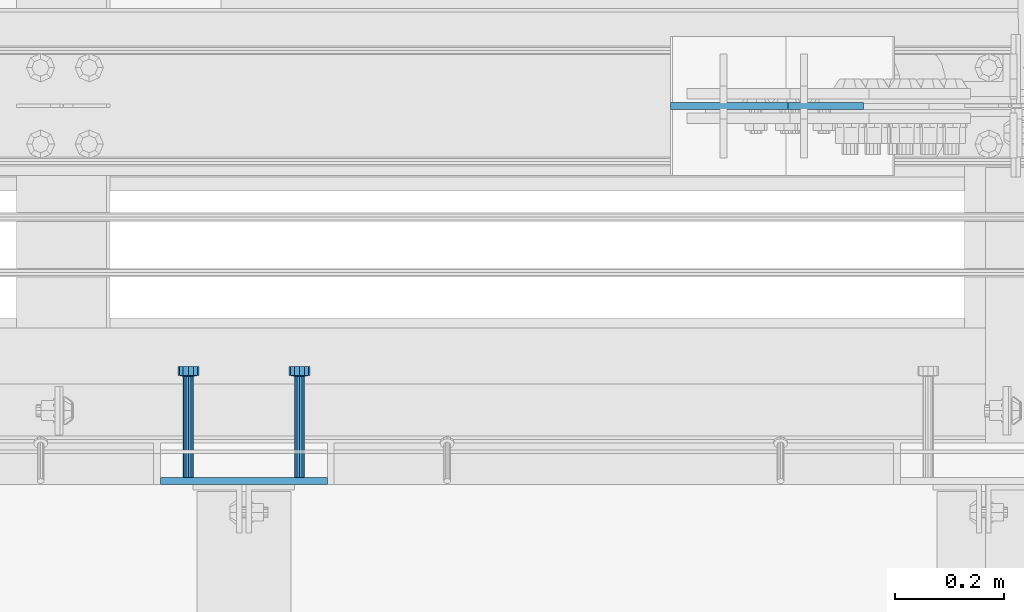
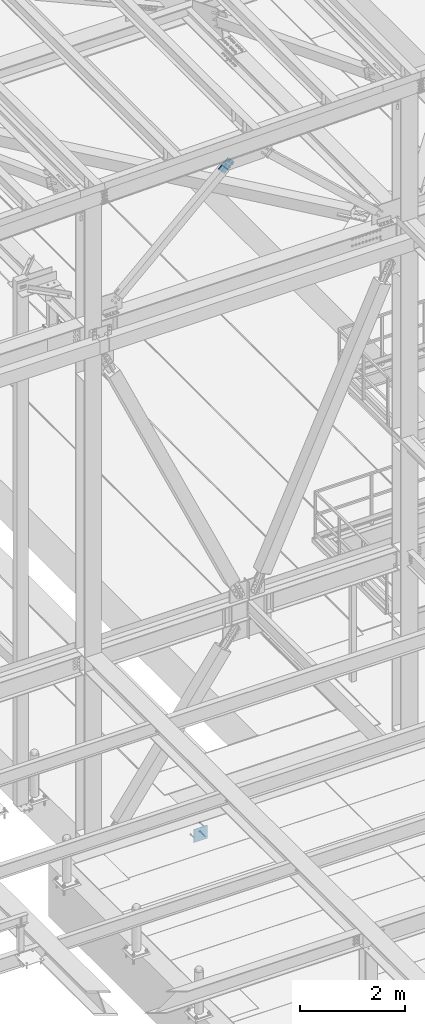
# One storey, part 2024 of 3843: 4 beams, 1 member, 2 elements without a shape of their own.
"""IFC2X3 building model written with IfcOpenShell, lengths in millimetres."""

from ifc_helpers import new_model, si_unit, frame, origin_with_axes, place, context, subcontext, project, spatial, faceted_brep, material, type_object, element, aggregate, save


model = new_model("IFC2X3")

# Units and contexts
model_context = context("Model", 3, precision=1e-05, world=origin_with_axes())
body_context = subcontext(model_context, "Body", "Model", "MODEL_VIEW")
ifc_project = project(units=[si_unit("LENGTHUNIT", "METRE", prefix="MILLI"), si_unit("AREAUNIT", "SQUARE_METRE"), si_unit("VOLUMEUNIT", "CUBIC_METRE"), si_unit("MASSUNIT", "GRAM", prefix="KILO"), si_unit("TIMEUNIT", "SECOND"), si_unit("PLANEANGLEUNIT", "RADIAN"), si_unit("SOLIDANGLEUNIT", "STERADIAN"), si_unit("THERMODYNAMICTEMPERATUREUNIT", "DEGREE_CELSIUS"), si_unit("LUMINOUSINTENSITYUNIT", "LUMEN")], contexts=[model_context])

# Site, building, storey
site_placement = place(None, origin_with_axes())
site = spatial("IfcSite", under=ifc_project, at=site_placement, CompositionType="ELEMENT")
building_placement = place(site_placement, origin_with_axes())
building = spatial("IfcBuilding", under=site, at=building_placement, Name="Undefined", CompositionType="ELEMENT")
storey_placement = place(building_placement, origin_with_axes())
storey = spatial("IfcBuildingStorey", under=building, at=storey_placement, Name="Undefined", CompositionType="ELEMENT", Elevation=0.0)

# Assembly, beam
assembly_1_placement = place(storey_placement, origin_with_axes())
assembly_1 = element("IfcElementAssembly", 1, at=assembly_1_placement, inside=storey, Name="EMBED PLATE", AssemblyPlace="NOTDEFINED", PredefinedType="RIGID_FRAME")
ifc_material_1 = material(Name="STEEL/A36")
beam_type_1 = type_object("IfcBeamType", PredefinedType="NOTDEFINED")
beam_1_placement = place(assembly_1_placement, frame((44122.975, 24930.0999969483, 30397.45), z_axis=(1.0, 0.0, 0.0), x_axis=(0.0, 0.0, -1.0)))
beam_1 = element("IfcBeam", 2, at=beam_1_placement, type_object=beam_type_1, material=ifc_material_1, Name="EMBED PLATE", context=body_context, shape_type="Brep", body=[
    faceted_brep([(-1.0550138540566e-10, 6.34999999999854, -152.400000000664), (1.0550138540566e-10, 6.34999999999854, 152.400000000656), (304.799999999999, 6.34999999999854, 152.400000000001), (304.799999999999, 6.34999999999854, -152.400000000001), (1.0550138540566e-10, -6.34999999999854, 152.400000000656), (304.799999999999, -6.34999999999854, 152.400000000001), (-1.0550138540566e-10, -6.34999999999854, -152.400000000664), (304.799999999999, -6.34999999999854, -152.400000000001)], [[[0, 1, 2, 3]], [[1, 4, 5, 2]], [[4, 6, 7, 5]], [[6, 0, 3, 7]], [[5, 7, 3, 2]], [[6, 4, 1, 0]]]),
])

# Assembly, member
assembly_2_placement = place(storey_placement, origin_with_axes())
assembly_2 = element("IfcElementAssembly", 3, at=assembly_2_placement, inside=storey, AssemblyPlace="NOTDEFINED", PredefinedType="RIGID_FRAME")
ifc_material_2 = material(Name="STEEL/A572-50")
member_type = type_object("IfcMemberType", PredefinedType="NOTDEFINED")
member_placement = place(assembly_2_placement, frame((45186.5607514104, 25615.8999999454, 45083.0309669652), z_axis=(0.678515287903944, 0.0, -0.734586280896007), x_axis=(-0.734586280896004, 0.0, -0.678515287903948)))
member = element("IfcMember", 4, at=member_placement, type_object=member_type, material=ifc_material_2, Name="PLATE", context=body_context, shape_type="Brep", body=[
    faceted_brep([(1.74622982740402e-10, 6.35000000000582, -101.600000000195), (-1.67347025126219e-10, 6.35000000000582, 101.600000000151), (292.1000000028, 6.35000000000582, 101.600000000661), (292.100000003156, 6.35000000000582, -101.599999999686), (-1.67347025126219e-10, -6.35000000000582, 101.600000000151), (292.1000000028, -6.35000000000582, 101.600000000661), (1.74622982740402e-10, -6.35000000000582, -101.600000000195), (292.100000003156, -6.35000000000582, -101.599999999686)], [[[0, 1, 2, 3]], [[1, 4, 5, 2]], [[4, 6, 7, 5]], [[6, 0, 3, 7]], [[5, 7, 3, 2]], [[6, 4, 1, 0]]]),
])
aggregate(assembly_2, [member])

# Beam
ifc_material_3 = material(Name="STEEL/A108")
beam_type_2 = type_object("IfcBeamType", PredefinedType="NOTDEFINED")
beam_2_placement = place(assembly_1_placement, frame((44021.375, 24936.4499969483, 30143.45), z_axis=(-1.0, 0.0, 0.0), x_axis=(0.0, 1.0, 0.0)))
beam_2 = element("IfcBeam", 5, at=beam_2_placement, type_object=beam_type_2, material=ifc_material_3, Name="HEADED STUD ANCHOR", context=body_context, shape_type="Brep", body=[
    faceted_brep([(0.0, -9.52000045776367, 0.0), (0.0, -8.25, -4.76000022888184), (184.912000000004, -8.25, -4.76000022888184), (184.912000000004, -9.52000045776367, 0.0), (0.0, -4.76000022888184, -8.25), (184.912000000004, -4.76000022888184, -8.25), (0.0, 0.0, -9.52000045776367), (184.912000000004, 0.0, -9.52000045776367), (0.0, 4.76000022888184, -8.25), (184.912000000004, 4.76000022888184, -8.25), (0.0, 8.25, -4.76000022888184), (184.912000000004, 8.25, -4.76000022888184), (0.0, 9.52000045776367, 0.0), (184.912000000004, 9.52000045776367, 0.0), (0.0, 8.25, 4.76000022888184), (184.912000000004, 8.25, 4.76000022888184), (0.0, 4.76000022888184, 8.25), (184.912000000004, 4.76000022888184, 8.25), (0.0, 0.0, 9.52000045776367), (184.912000000004, 0.0, 9.52000045776367), (0.0, -4.76000022888184, 8.25), (184.912000000004, -4.76000022888184, 8.25), (0.0, -8.25, 4.76000022888184), (184.912000000004, -8.25, 4.76000022888184), (186.944000000003, -16.5, -9.52000045776367), (186.944000000003, -19.0499992370605, 0.0), (186.944000000003, -9.52000045776367, -16.5), (186.944000000003, 0.0, -19.0499992370605), (186.944000000003, 9.52000045776367, -16.5), (186.944000000003, 16.5, -9.52000045776367), (186.944000000003, 19.0499992370605, 0.0), (186.944000000003, 16.5, 9.52000045776367), (186.944000000003, 9.52000045776367, 16.5), (186.944000000003, 0.0, 19.0499992370605), (186.944000000003, -9.52000045776367, 16.5), (186.944000000003, -16.5, 9.52000045776367), (203.199999999997, -16.5, -9.52000045776367), (203.199999999997, -19.0499992370605, 0.0), (203.199999999997, -9.52000045776367, -16.5), (203.199999999997, 0.0, -19.0499992370605), (203.199999999997, 9.52000045776367, -16.5), (203.199999999997, 16.5, -9.52000045776367), (203.199999999997, 19.0499992370605, 0.0), (203.199999999997, 16.5, 9.52000045776367), (203.199999999997, 9.52000045776367, 16.5), (203.199999999997, 0.0, 19.0499992370605), (203.199999999997, -9.52000045776367, 16.5), (203.199999999997, -16.5, 9.52000045776367)], [[[0, 1, 2, 3]], [[1, 4, 5, 2]], [[4, 6, 7, 5]], [[6, 8, 9, 7]], [[8, 10, 11, 9]], [[10, 12, 13, 11]], [[12, 14, 15, 13]], [[14, 16, 17, 15]], [[16, 18, 19, 17]], [[18, 20, 21, 19]], [[20, 22, 23, 21]], [[22, 0, 3, 23]], [[22, 20, 18, 16, 14, 12, 10, 8, 6, 4, 1, 0]], [[3, 2, 24, 25]], [[2, 5, 26, 24]], [[5, 7, 27, 26]], [[7, 9, 28, 27]], [[9, 11, 29, 28]], [[11, 13, 30, 29]], [[13, 15, 31, 30]], [[15, 17, 32, 31]], [[17, 19, 33, 32]], [[19, 21, 34, 33]], [[21, 23, 35, 34]], [[23, 3, 25, 35]], [[25, 24, 36, 37]], [[24, 26, 38, 36]], [[26, 27, 39, 38]], [[27, 28, 40, 39]], [[28, 29, 41, 40]], [[29, 30, 42, 41]], [[30, 31, 43, 42]], [[31, 32, 44, 43]], [[32, 33, 45, 44]], [[33, 34, 46, 45]], [[34, 35, 47, 46]], [[35, 25, 37, 47]], [[38, 39, 40, 41, 42, 43, 44, 45, 46, 47, 37, 36]]]),
])

beam_3_placement = place(assembly_1_placement, frame((44224.575, 24936.4499969483, 30346.65), z_axis=(-1.0, 0.0, 0.0), x_axis=(0.0, 1.0, 0.0)))
beam_3 = element("IfcBeam", 6, at=beam_3_placement, type_object=beam_type_2, material=ifc_material_1, Name="PLATE", context=body_context, shape_type="Brep", body=[
    faceted_brep([(0.0, -9.52000045776367, 0.0), (0.0, -8.25, -4.76000022888184), (184.912000000004, -8.25, -4.76000022888184), (184.912000000004, -9.52000045776367, 0.0), (0.0, -4.76000022888184, -8.25), (184.912000000004, -4.76000022888184, -8.25), (0.0, 0.0, -9.52000045776367), (184.912000000004, 0.0, -9.52000045776367), (0.0, 4.76000022888184, -8.25), (184.912000000004, 4.76000022888184, -8.25), (0.0, 8.25, -4.76000022888184), (184.912000000004, 8.25, -4.76000022888184), (0.0, 9.52000045776367, 0.0), (184.912000000004, 9.52000045776367, 0.0), (0.0, 8.25, 4.76000022888184), (184.912000000004, 8.25, 4.76000022888184), (0.0, 4.76000022888184, 8.25), (184.912000000004, 4.76000022888184, 8.25), (0.0, 0.0, 9.52000045776367), (184.912000000004, 0.0, 9.52000045776367), (0.0, -4.76000022888184, 8.25), (184.912000000004, -4.76000022888184, 8.25), (0.0, -8.25, 4.76000022888184), (184.912000000004, -8.25, 4.76000022888184), (186.944000000003, -16.5, -9.52000045776367), (186.944000000003, -19.0499992370605, 0.0), (186.944000000003, -9.52000045776367, -16.5), (186.944000000003, 0.0, -19.0499992370605), (186.944000000003, 9.52000045776367, -16.5), (186.944000000003, 16.5, -9.52000045776367), (186.944000000003, 19.0499992370605, 0.0), (186.944000000003, 16.5, 9.52000045776367), (186.944000000003, 9.52000045776367, 16.5), (186.944000000003, 0.0, 19.0499992370605), (186.944000000003, -9.52000045776367, 16.5), (186.944000000003, -16.5, 9.52000045776367), (203.199999999997, -16.5, -9.52000045776367), (203.199999999997, -19.0499992370605, 0.0), (203.199999999997, -9.52000045776367, -16.5), (203.199999999997, 0.0, -19.0499992370605), (203.199999999997, 9.52000045776367, -16.5), (203.199999999997, 16.5, -9.52000045776367), (203.199999999997, 19.0499992370605, 0.0), (203.199999999997, 16.5, 9.52000045776367), (203.199999999997, 9.52000045776367, 16.5), (203.199999999997, 0.0, 19.0499992370605), (203.199999999997, -9.52000045776367, 16.5), (203.199999999997, -16.5, 9.52000045776367)], [[[0, 1, 2, 3]], [[1, 4, 5, 2]], [[4, 6, 7, 5]], [[6, 8, 9, 7]], [[8, 10, 11, 9]], [[10, 12, 13, 11]], [[12, 14, 15, 13]], [[14, 16, 17, 15]], [[16, 18, 19, 17]], [[18, 20, 21, 19]], [[20, 22, 23, 21]], [[22, 0, 3, 23]], [[22, 20, 18, 16, 14, 12, 10, 8, 6, 4, 1, 0]], [[3, 2, 24, 25]], [[2, 5, 26, 24]], [[5, 7, 27, 26]], [[7, 9, 28, 27]], [[9, 11, 29, 28]], [[11, 13, 30, 29]], [[13, 15, 31, 30]], [[15, 17, 32, 31]], [[17, 19, 33, 32]], [[19, 21, 34, 33]], [[21, 23, 35, 34]], [[23, 3, 25, 35]], [[25, 24, 36, 37]], [[24, 26, 38, 36]], [[26, 27, 39, 38]], [[27, 28, 40, 39]], [[28, 29, 41, 40]], [[29, 30, 42, 41]], [[30, 31, 43, 42]], [[31, 32, 44, 43]], [[32, 33, 45, 44]], [[33, 34, 46, 45]], [[34, 35, 47, 46]], [[35, 25, 37, 47]], [[38, 39, 40, 41, 42, 43, 44, 45, 46, 47, 37, 36]]]),
])

beam_4_placement = place(assembly_1_placement, frame((44224.575, 24936.4499969483, 30143.45), z_axis=(-1.0, 0.0, 0.0), x_axis=(0.0, 1.0, 0.0)))
beam_4 = element("IfcBeam", 7, at=beam_4_placement, type_object=beam_type_2, material=ifc_material_3, Name="HEADED STUD ANCHOR", context=body_context, shape_type="Brep", body=[
    faceted_brep([(0.0, -9.52000045776367, 0.0), (0.0, -8.25, -4.76000022888184), (184.912000000004, -8.25, -4.76000022888184), (184.912000000004, -9.52000045776367, 0.0), (0.0, -4.76000022888184, -8.25), (184.912000000004, -4.76000022888184, -8.25), (0.0, 0.0, -9.52000045776367), (184.912000000004, 0.0, -9.52000045776367), (0.0, 4.76000022888184, -8.25), (184.912000000004, 4.76000022888184, -8.25), (0.0, 8.25, -4.76000022888184), (184.912000000004, 8.25, -4.76000022888184), (0.0, 9.52000045776367, 0.0), (184.912000000004, 9.52000045776367, 0.0), (0.0, 8.25, 4.76000022888184), (184.912000000004, 8.25, 4.76000022888184), (0.0, 4.76000022888184, 8.25), (184.912000000004, 4.76000022888184, 8.25), (0.0, 0.0, 9.52000045776367), (184.912000000004, 0.0, 9.52000045776367), (0.0, -4.76000022888184, 8.25), (184.912000000004, -4.76000022888184, 8.25), (0.0, -8.25, 4.76000022888184), (184.912000000004, -8.25, 4.76000022888184), (186.944000000003, -16.5, -9.52000045776367), (186.944000000003, -19.0499992370605, 0.0), (186.944000000003, -9.52000045776367, -16.5), (186.944000000003, 0.0, -19.0499992370605), (186.944000000003, 9.52000045776367, -16.5), (186.944000000003, 16.5, -9.52000045776367), (186.944000000003, 19.0499992370605, 0.0), (186.944000000003, 16.5, 9.52000045776367), (186.944000000003, 9.52000045776367, 16.5), (186.944000000003, 0.0, 19.0499992370605), (186.944000000003, -9.52000045776367, 16.5), (186.944000000003, -16.5, 9.52000045776367), (203.199999999997, -16.5, -9.52000045776367), (203.199999999997, -19.0499992370605, 0.0), (203.199999999997, -9.52000045776367, -16.5), (203.199999999997, 0.0, -19.0499992370605), (203.199999999997, 9.52000045776367, -16.5), (203.199999999997, 16.5, -9.52000045776367), (203.199999999997, 19.0499992370605, 0.0), (203.199999999997, 16.5, 9.52000045776367), (203.199999999997, 9.52000045776367, 16.5), (203.199999999997, 0.0, 19.0499992370605), (203.199999999997, -9.52000045776367, 16.5), (203.199999999997, -16.5, 9.52000045776367)], [[[0, 1, 2, 3]], [[1, 4, 5, 2]], [[4, 6, 7, 5]], [[6, 8, 9, 7]], [[8, 10, 11, 9]], [[10, 12, 13, 11]], [[12, 14, 15, 13]], [[14, 16, 17, 15]], [[16, 18, 19, 17]], [[18, 20, 21, 19]], [[20, 22, 23, 21]], [[22, 0, 3, 23]], [[22, 20, 18, 16, 14, 12, 10, 8, 6, 4, 1, 0]], [[3, 2, 24, 25]], [[2, 5, 26, 24]], [[5, 7, 27, 26]], [[7, 9, 28, 27]], [[9, 11, 29, 28]], [[11, 13, 30, 29]], [[13, 15, 31, 30]], [[15, 17, 32, 31]], [[17, 19, 33, 32]], [[19, 21, 34, 33]], [[21, 23, 35, 34]], [[23, 3, 25, 35]], [[25, 24, 36, 37]], [[24, 26, 38, 36]], [[26, 27, 39, 38]], [[27, 28, 40, 39]], [[28, 29, 41, 40]], [[29, 30, 42, 41]], [[30, 31, 43, 42]], [[31, 32, 44, 43]], [[32, 33, 45, 44]], [[33, 34, 46, 45]], [[34, 35, 47, 46]], [[35, 25, 37, 47]], [[38, 39, 40, 41, 42, 43, 44, 45, 46, 47, 37, 36]]]),
])

aggregate(assembly_1, [beam_2, beam_3, beam_4, beam_1])

save(model, "model.ifc")
